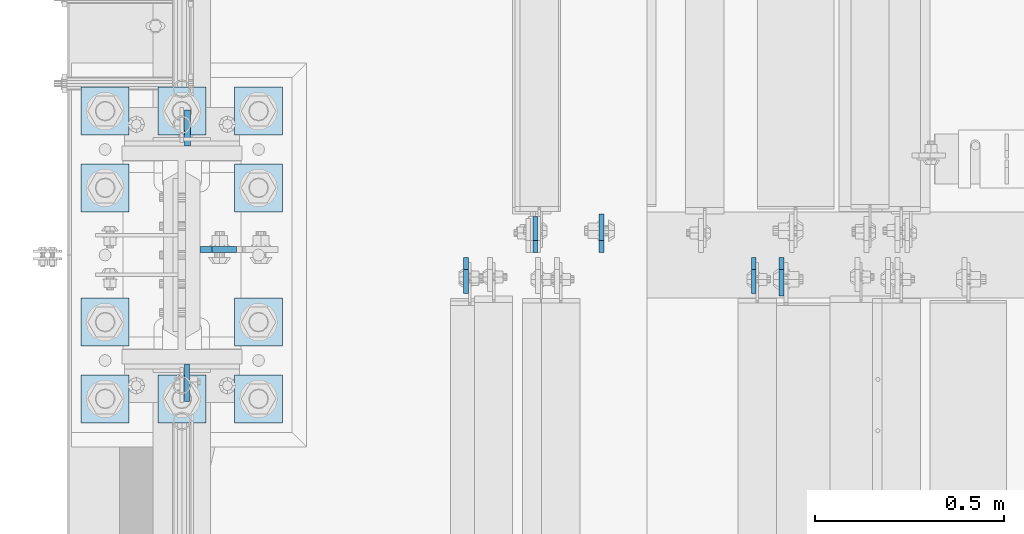
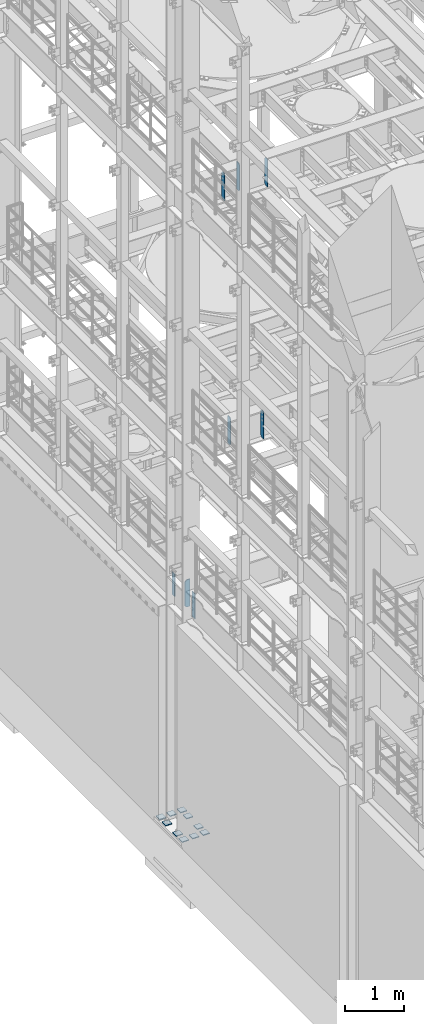
# One storey, part 1694 of 1876: 18 plates, 4 elements without a shape of their own.
"""IFC2X3 building model written with IfcOpenShell, lengths in millimetres."""

import ifcopenshell
import ifcopenshell.guid

model = None  # the IFC model being written
_history = None  # IfcOwnerHistory: only IFC2X3 demands one
_inside = {}  # id of a spatial element -> (the spatial element, [elements in it])
_under = {}  # id of a project, library or spatial element -> (it, [spatial elements below it])
_declared = {}  # id of a project -> (the project, [libraries it declares])
_typed = {}  # id of a type object -> (the type object, [elements of that type])
_made_of = {}  # id of a material, layer set ... -> (it, [elements and type objects made of it])


def new_model(schema):
    """Start an empty IFC model of exactly this schema.

    Asked for "IFC4X3", IfcOpenShell would pick the latest addendum, in which some entities
    have other attributes; the version numbers below select the first issue.
    IFC2X3 requires an IfcOwnerHistory on every rooted entity: one is made here for all.
    """
    global model, _history
    if schema == "IFC4X3":
        model = ifcopenshell.file(schema_version=(4, 3, 0, 0))
    else:
        model = ifcopenshell.file(schema=schema)
    _inside.clear()
    _under.clear()
    _declared.clear()
    _typed.clear()
    _made_of.clear()
    _history = None
    if model.schema == "IFC2X3":
        org = make("IfcOrganization", Name="unknown")
        user = make(
            "IfcPersonAndOrganization",
            ThePerson=make("IfcPerson", FamilyName="unknown"),
            TheOrganization=org,
        )
        app = make(
            "IfcApplication",
            ApplicationDeveloper=org,
            Version="unknown",
            ApplicationFullName="unknown",
            ApplicationIdentifier="unknown",
        )
        _history = make(
            "IfcOwnerHistory",
            OwningUser=user,
            OwningApplication=app,
            ChangeAction="ADDED",
            CreationDate=0,
        )
    return model


def make(cls, **values):
    """One entity of the class cls with the attributes given. An attribute that is None is left unset."""
    return model.create_entity(
        cls, **{name: value for name, value in values.items() if value is not None}
    )


def rooted(cls, **values):
    """An entity with a GlobalId (a new one), such as an element, a storey or a relation."""
    return make(cls, GlobalId=ifcopenshell.guid.new(), OwnerHistory=_history, **values)


def si_unit(unit_type, name, prefix=None):
    """IfcSIUnit, for example si_unit("LENGTHUNIT", "METRE", prefix="MILLI")."""
    return make("IfcSIUnit", UnitType=unit_type, Prefix=prefix, Name=name)


def assignment(units):
    """IfcUnitAssignment: the units of a project."""
    return None if units is None else make("IfcUnitAssignment", Units=units)


def point(xyz):
    """IfcCartesianPoint."""
    return None if xyz is None else make("IfcCartesianPoint", Coordinates=xyz)


def direction(xyz):
    """IfcDirection."""
    return None if xyz is None else make("IfcDirection", DirectionRatios=xyz)


def frame(location, z_axis=None, x_axis=None):
    """IfcAxis2Placement3D, a coordinate frame: its origin and axes. An axis left out is left unset."""
    return make(
        "IfcAxis2Placement3D",
        Location=point(location),
        Axis=direction(z_axis),
        RefDirection=direction(x_axis),
    )


def origin_with_axes():
    """The frame at (0, 0, 0) with the z axis (0, 0, 1) and the x axis (1, 0, 0) written out."""
    return frame((0.0, 0.0, 0.0), z_axis=(0.0, 0.0, 1.0), x_axis=(1.0, 0.0, 0.0))


def place(relative_to, where):
    """IfcLocalPlacement: puts the frame where relative to a parent placement (None: the world)."""
    return make(
        "IfcLocalPlacement", PlacementRelTo=relative_to, RelativePlacement=where
    )


def context(
    kind, dimensions, precision=None, world=None, true_north=None, identifier=None
):
    """IfcGeometricRepresentationContext, for example the 3D "Model" context."""
    return make(
        "IfcGeometricRepresentationContext",
        ContextIdentifier=identifier,
        ContextType=kind,
        CoordinateSpaceDimension=dimensions,
        Precision=precision,
        WorldCoordinateSystem=world,
        TrueNorth=true_north,
    )


def subcontext(parent, identifier, kind, view, scale=None):
    """IfcGeometricRepresentationSubContext, for example "Body" below "Model"."""
    return make(
        "IfcGeometricRepresentationSubContext",
        ContextIdentifier=identifier,
        ContextType=kind,
        ParentContext=parent,
        TargetScale=scale,
        TargetView=view,
    )


def project(units=None, contexts=None):
    """IfcProject with its units and contexts."""
    return rooted(
        "IfcProject",
        Name="project",
        RepresentationContexts=contexts,
        UnitsInContext=assignment(units),
    )


def spatial(cls, under=None, at=None, **own):
    """A site, building, storey or space (cls), placed at a placement, below another one or the project."""
    s = rooted(cls, ObjectPlacement=at, **own)
    if under is not None:
        _under.setdefault(under.id(), (under, []))[1].append(s)
    return s


def faces_of(points, faces, orient=None, outer=None):
    """IfcFace entities. A face is a list of loops; a loop is a list of indices into points, from 0.

    orient and outer hold one flag for each loop. By default every Orientation is true, the
    first loop of a face is its IfcFaceOuterBound and the others are IfcFaceBound.
    """
    made = []
    for i, loops in enumerate(faces):
        bounds = []
        for j, loop in enumerate(loops):
            is_outer = j == 0 if outer is None else outer[i][j]
            bounds.append(
                make(
                    "IfcFaceOuterBound" if is_outer else "IfcFaceBound",
                    Bound=make("IfcPolyLoop", Polygon=[points[k] for k in loop]),
                    Orientation=True if orient is None else orient[i][j],
                )
            )
        made.append(make("IfcFace", Bounds=bounds))
    return made


def faceted_brep(points, faces, orient=None, outer=None, voids=None):
    """IfcFacetedBrep: a solid bounded by flat faces; with voids (closed shells), ...WithVoids."""
    shared = [point(p) for p in points]
    hull = make("IfcClosedShell", CfsFaces=faces_of(shared, faces, orient, outer))
    if voids is None:
        return make("IfcFacetedBrep", Outer=hull)
    return make(
        "IfcFacetedBrepWithVoids",
        Outer=hull,
        Voids=[
            make(cls, CfsFaces=faces_of(shared, fs, o, b)) for cls, fs, o, b in voids
        ],
    )


def shape(context_of_items, identifier, shape_type, items):
    """IfcShapeRepresentation: the items that make up one representation, for example the "Body"."""
    return make(
        "IfcShapeRepresentation",
        ContextOfItems=context_of_items,
        RepresentationIdentifier=identifier,
        RepresentationType=shape_type,
        Items=items,
    )


def material(Name=None, Category=None):
    """IfcMaterial."""
    return make("IfcMaterial", Name=Name, Category=Category)


def made_of(thing, what):
    """Note that an element or type object is made of a material, layer set ...; save() writes the relation."""
    if what is not None:
        _made_of.setdefault(what.id(), (what, []))[1].append(thing)
    return thing


def type_object(cls, material=None, **own):
    """A type object (cls), such as IfcWallType, which elements share."""
    return made_of(rooted(cls, **own), material)


def element(
    cls,
    number,
    at=None,
    inside=None,
    cuts=None,
    type_object=None,
    material=None,
    context=None,
    identifier="Body",
    shape_type=None,
    held_by="IfcProductDefinitionShape",
    body=None,
    shapes=None,
    **own,
):
    """One element of the class cls, such as IfcWall. Its Tag is "e" and its number.

    at: its placement. inside: the storey or other place that contains it. cuts: it is an
    opening in that element (IfcRelVoidsElement). A single representation is given by context,
    identifier, shape_type and body (its items); several are given by shapes. held_by: the class
    of the entity that holds the representations. save() writes the other relations.
    """
    e = rooted(cls, Tag="e%d" % number, ObjectPlacement=at, **own)
    if body is not None:
        shapes = [shape(context, identifier, shape_type, body)]
    if shapes is not None:
        e.Representation = make(held_by, Representations=shapes)
    if inside is not None:
        _inside.setdefault(inside.id(), (inside, []))[1].append(e)
    if cuts is not None:
        rooted(
            "IfcRelVoidsElement", RelatingBuildingElement=cuts, RelatedOpeningElement=e
        )
    if type_object is not None:
        _typed.setdefault(type_object.id(), (type_object, []))[1].append(e)
    return made_of(e, material)


def aggregate(whole, parts):
    """IfcRelAggregates: a whole, such as a stair, and the parts it consists of."""
    return rooted("IfcRelAggregates", RelatingObject=whole, RelatedObjects=parts)


def save(model, path):
    """Write the relations noted so far, then the file.

    IfcRelAggregates (storeys below a building ...), IfcRelContainedInSpatialStructure (elements
    in a storey), IfcRelDefinesByType, IfcRelAssociatesMaterial and IfcRelDeclares: one each for
    every whole, place, type object, material and project.
    """
    for whole, parts in _under.values():
        aggregate(whole, parts)
    for where, things in _inside.values():
        rooted(
            "IfcRelContainedInSpatialStructure",
            RelatedElements=things,
            RelatingStructure=where,
        )
    for kind, things in _typed.values():
        rooted("IfcRelDefinesByType", RelatedObjects=things, RelatingType=kind)
    for what, things in _made_of.values():
        rooted("IfcRelAssociatesMaterial", RelatedObjects=things, RelatingMaterial=what)
    for by, libraries in _declared.values():
        rooted("IfcRelDeclares", RelatingContext=by, RelatedDefinitions=libraries)
    model.write(path)


model = new_model("IFC2X3")

# Units and contexts
model_context = context("Model", 3, precision=1e-05, world=origin_with_axes())
body_context = subcontext(model_context, "Body", "Model", "MODEL_VIEW")
ifc_project = project(units=[si_unit("LENGTHUNIT", "METRE", prefix="MILLI"), si_unit("AREAUNIT", "SQUARE_METRE"), si_unit("VOLUMEUNIT", "CUBIC_METRE"), si_unit("MASSUNIT", "GRAM", prefix="KILO"), si_unit("TIMEUNIT", "SECOND"), si_unit("PLANEANGLEUNIT", "RADIAN"), si_unit("SOLIDANGLEUNIT", "STERADIAN"), si_unit("THERMODYNAMICTEMPERATUREUNIT", "DEGREE_CELSIUS"), si_unit("LUMINOUSINTENSITYUNIT", "LUMEN")], contexts=[model_context])

# Site, building, storey
site_placement = place(None, origin_with_axes())
site = spatial("IfcSite", under=ifc_project, at=site_placement, CompositionType="ELEMENT")
building_placement = place(site_placement, origin_with_axes())
building = spatial("IfcBuilding", under=site, at=building_placement, Name="Undefined", CompositionType="ELEMENT")
storey_placement = place(building_placement, origin_with_axes())
storey = spatial("IfcBuildingStorey", under=building, at=storey_placement, Name="Undefined", CompositionType="ELEMENT", Elevation=0.0)

# Assembly, plate
assembly_1_placement = place(storey_placement, origin_with_axes())
assembly_1 = element("IfcElementAssembly", 1, at=assembly_1_placement, inside=storey, Name="COLUMN", AssemblyPlace="NOTDEFINED", PredefinedType="RIGID_FRAME")
ifc_material_1 = material(Name="STEEL/A572-50")
plate_type_1 = type_object("IfcPlateType", PredefinedType="NOTDEFINED")
plate_1_placement = place(assembly_1_placement, frame((13.493000125885, 7331.075, 5076.825), z_axis=(0.0, -1.0, 0.0), x_axis=(0.0, 0.0, -1.0)))
plate_1 = element("IfcPlate", 2, at=plate_1_placement, type_object=plate_type_1, material=ifc_material_1, Name="PLATE", context=body_context, shape_type="Brep", body=[
    faceted_brep([(0.0, -6.35000000000036, 0.0), (0.0, -6.34999999999991, 98.4250030517578), (0.0, 6.34999999999991, 98.4250030517578), (0.0, 6.35000000000036, 0.0), (514.349975585938, -6.35000000000036, 98.4250030517578), (514.349975585938, 6.35000000000036, 98.4250030517578), (514.349975585938, -6.35000000000036, 0.0), (514.349975585938, 6.35000000000036, 0.0)], [[[0, 1, 2, 3]], [[1, 4, 5, 2]], [[4, 6, 7, 5]], [[6, 0, 3, 7]], [[5, 7, 3, 2]], [[6, 4, 1, 0]]]),
])

# Assembly, plates
assembly_2_placement = place(storey_placement, origin_with_axes())
assembly_2 = element("IfcElementAssembly", 3, at=assembly_2_placement, inside=storey, Name="BEAM", AssemblyPlace="NOTDEFINED", PredefinedType="RIGID_FRAME")
ifc_material_2 = material(Name="STEEL/A36")
plate_type_2 = type_object("IfcPlateType", PredefinedType="NOTDEFINED")
plate_2_placement = place(assembly_2_placement, frame((1514.47512197494, 7612.85625, 7558.0875), z_axis=(0.0, 0.0, 1.0), x_axis=(0.0, -1.0, 0.0)))
plate_2 = element("IfcPlate", 4, at=plate_2_placement, type_object=plate_type_2, material=ifc_material_2, Name="PLATE", context=body_context, shape_type="Brep", body=[
    faceted_brep([(0.0, -6.34999999999991, 31.75), (0.0, -6.35000000000036, 538.162475585938), (0.0, 6.35000000000036, 538.162475585938), (0.0, 6.34999999999991, 31.75), (31.75, -6.35000000000036, 569.912475585938), (31.75, 6.35000000000036, 569.912475585938), (95.25, -6.35000000000036, 569.912475585938), (95.25, 6.35000000000036, 569.912475585938), (95.25, -6.35000000000036, 0.0), (95.25, 6.35000000000036, 0.0), (31.75, -6.34999999999991, 0.0), (31.75, 6.34999999999991, 0.0)], [[[0, 1, 2, 3]], [[1, 4, 5, 2]], [[4, 6, 7, 5]], [[6, 8, 9, 7]], [[8, 10, 11, 9]], [[10, 0, 3, 11]], [[5, 7, 9, 11, 3, 2]], [[10, 8, 6, 4, 1, 0]]]),
])
plate_3_placement = place(assembly_2_placement, frame((936.624999904632, 7627.14375, 7558.0875), z_axis=(0.0, 0.0, 1.0), x_axis=(0.0, 1.0, 0.0)))
plate_3 = element("IfcPlate", 5, at=plate_3_placement, type_object=plate_type_2, material=ifc_material_2, Name="PLATE", context=body_context, shape_type="Brep", body=[
    faceted_brep([(0.0, -6.34999999999991, 31.75), (0.0, -6.35000000000036, 538.162475585938), (0.0, 6.35000000000036, 538.162475585938), (0.0, 6.34999999999991, 31.75), (31.75, -6.35000000000036, 569.912475585938), (31.75, 6.35000000000036, 569.912475585938), (95.25, -6.35000000000036, 569.912475585938), (95.25, 6.35000000000036, 569.912475585938), (95.25, -6.35000000000036, 0.0), (95.25, 6.35000000000036, 0.0), (31.75, -6.34999999999991, 0.0), (31.75, 6.34999999999991, 0.0)], [[[0, 1, 2, 3]], [[1, 4, 5, 2]], [[4, 6, 7, 5]], [[6, 8, 9, 7]], [[8, 10, 11, 9]], [[10, 0, 3, 11]], [[5, 7, 9, 11, 3, 2]], [[10, 8, 6, 4, 1, 0]]]),
])
aggregate(assembly_2, [plate_2, plate_3])

assembly_3_placement = place(storey_placement, origin_with_axes())
assembly_3 = element("IfcElementAssembly", 6, at=assembly_3_placement, inside=storey, Name="BEAM", AssemblyPlace="NOTDEFINED", PredefinedType="RIGID_FRAME")
plate_4_placement = place(assembly_3_placement, frame((752.474999904632, 7612.85625, 12714.2875), z_axis=(0.0, 0.0, 1.0), x_axis=(0.0, -1.0, 0.0)))
plate_4 = element("IfcPlate", 7, at=plate_4_placement, type_object=plate_type_2, material=ifc_material_2, Name="PLATE", context=body_context, shape_type="Brep", body=[
    faceted_brep([(0.0, -6.34999999999991, 31.75), (0.0, -6.35000000000036, 538.162475585938), (0.0, 6.35000000000036, 538.162475585938), (0.0, 6.34999999999991, 31.75), (31.75, -6.35000000000036, 569.912475585938), (31.75, 6.35000000000036, 569.912475585938), (95.25, -6.35000000000036, 569.912475585938), (95.25, 6.35000000000036, 569.912475585938), (95.25, -6.35000000000036, 0.0), (95.25, 6.35000000000036, 0.0), (31.75, -6.34999999999991, 0.0), (31.75, 6.34999999999991, 0.0)], [[[0, 1, 2, 3]], [[1, 4, 5, 2]], [[4, 6, 7, 5]], [[6, 8, 9, 7]], [[8, 10, 11, 9]], [[10, 0, 3, 11]], [[5, 7, 9, 11, 3, 2]], [[10, 8, 6, 4, 1, 0]]]),
])
plate_type_3 = type_object("IfcPlateType", PredefinedType="NOTDEFINED")
plate_5_placement = place(assembly_3_placement, frame((1111.25000470527, 7627.14375, 12714.2875), z_axis=(0.0, 0.0, 1.0), x_axis=(0.0, 1.0, 0.0)))
plate_5 = element("IfcPlate", 8, at=plate_5_placement, type_object=plate_type_3, material=ifc_material_2, Name="PLATE", context=body_context, shape_type="Brep", body=[
    faceted_brep([(0.0, -6.34999999999991, 31.75), (0.0, -6.35000000000036, 538.162475585938), (0.0, 6.35000000000036, 538.162475585938), (0.0, 6.34999999999991, 31.75), (31.75, -6.35000000000036, 569.912475585938), (31.75, 6.35000000000036, 569.912475585938), (101.599998474121, -6.34999999999991, 569.912475585938), (101.599998474121, 6.34999999999991, 569.912475585938), (101.599998474121, -6.35000000000036, 0.0), (101.599998474121, 6.35000000000036, 0.0), (31.75, -6.34999999999991, 0.0), (31.75, 6.34999999999991, 0.0)], [[[0, 1, 2, 3]], [[1, 4, 5, 2]], [[4, 6, 7, 5]], [[6, 8, 9, 7]], [[8, 10, 11, 9]], [[10, 0, 3, 11]], [[5, 7, 9, 11, 3, 2]], [[10, 8, 6, 4, 1, 0]]]),
])
plate_6_placement = place(assembly_3_placement, frame((1588.29374990463, 7612.85625, 12714.2875), z_axis=(0.0, 0.0, 1.0), x_axis=(0.0, -1.0, 0.0)))
plate_6 = element("IfcPlate", 9, at=plate_6_placement, type_object=plate_type_3, material=ifc_material_2, Name="PLATE", context=body_context, shape_type="Brep", body=[
    faceted_brep([(0.0, -6.34999999999991, 31.75), (0.0, -6.35000000000036, 538.162475585938), (0.0, 6.35000000000036, 538.162475585938), (0.0, 6.34999999999991, 31.75), (31.75, -6.35000000000036, 569.912475585938), (31.75, 6.35000000000036, 569.912475585938), (101.599998474121, -6.34999999999991, 569.912475585938), (101.599998474121, 6.34999999999991, 569.912475585938), (101.599998474121, -6.35000000000036, 0.0), (101.599998474121, 6.35000000000036, 0.0), (31.75, -6.34999999999991, 0.0), (31.75, 6.34999999999991, 0.0)], [[[0, 1, 2, 3]], [[1, 4, 5, 2]], [[4, 6, 7, 5]], [[6, 8, 9, 7]], [[8, 10, 11, 9]], [[10, 0, 3, 11]], [[5, 7, 9, 11, 3, 2]], [[10, 8, 6, 4, 1, 0]]]),
])
aggregate(assembly_3, [plate_5, plate_4, plate_6])

# Plate
plate_type_4 = type_object("IfcPlateType", PredefinedType="NOTDEFINED")
plate_7_placement = place(assembly_1_placement, frame((48.4187500000005, 7635.08050012589, 5099.05), z_axis=(1.0, 0.0, 0.0), x_axis=(0.0, 0.0, -1.0)))
plate_7 = element("IfcPlate", 10, at=plate_7_placement, type_object=plate_type_4, material=ifc_material_2, Name="PLATE", context=body_context, shape_type="Brep", body=[
    faceted_brep([(0.0, -7.93749999999998, 31.75), (0.0, -7.9375, 96.0437469482422), (0.0, 7.9375, 96.0437469482422), (0.0, 7.93749999999999, 31.75), (558.799987792969, -7.9375, 96.0437469482422), (558.799987792969, 7.9375, 96.0437469482422), (558.799987792969, -7.93749999999998, 31.75), (558.799987792969, 7.93749999999999, 31.75), (527.049987792969, -7.93749999999998, 0.0), (527.049987792969, 7.93749999999999, 0.0), (31.75, -7.93749999999998, 0.0), (31.75, 7.93749999999999, 0.0)], [[[0, 1, 2, 3]], [[1, 4, 5, 2]], [[4, 6, 7, 5]], [[6, 8, 9, 7]], [[8, 10, 11, 9]], [[10, 0, 3, 11]], [[5, 7, 9, 11, 3, 2]], [[10, 8, 6, 4, 1, 0]]]),
])

plate_8_placement = place(assembly_1_placement, frame((15.080500125885, 7908.925, 5067.3), z_axis=(0.0, 1.0, 0.0), x_axis=(0.0, 0.0, -1.0)))
plate_8 = element("IfcPlate", 11, at=plate_8_placement, type_object=plate_type_4, material=ifc_material_2, Name="PLATE", context=body_context, shape_type="Brep", body=[
    faceted_brep([(0.0, -7.9375, 0.0), (0.0, -7.9375, 95.25), (0.0, 7.9375, 95.25), (0.0, 7.9375, 0.0), (457.200012207031, -7.9375, 95.25), (457.200012207031, 7.9375, 95.25), (457.200012207031, -7.9375, 0.0), (457.200012207031, 7.9375, 0.0)], [[[0, 1, 2, 3]], [[1, 4, 5, 2]], [[4, 6, 7, 5]], [[6, 0, 3, 7]], [[5, 7, 3, 2]], [[6, 4, 1, 0]]]),
])

aggregate(assembly_1, [plate_7, plate_1, plate_8])

# Assembly, plates
assembly_4_placement = place(storey_placement, origin_with_axes())
assembly_4 = element("IfcElementAssembly", 12, at=assembly_4_placement, inside=storey, Name="TEMPLATE", AssemblyPlace="NOTDEFINED", PredefinedType="RIGID_FRAME")
plate_type_5 = type_object("IfcPlateType", PredefinedType="NOTDEFINED")
plate_9_placement = place(assembly_4_placement, frame((-139.7, 7302.5, 104.775), z_axis=(-1.0, 0.0, 0.0), x_axis=(0.0, -1.0, 0.0)))
plate_9 = element("IfcPlate", 13, at=plate_9_placement, type_object=plate_type_5, material=ifc_material_1, Name="PLATE WASHER", context=body_context, shape_type="Brep", body=[
    faceted_brep([(-9.09494701772928e-13, -9.525, -1.81898940354586e-12), (0.0, -9.52500000000001, 127.0), (0.0, 9.52500000000001, 127.0), (-9.09494701772928e-13, 9.525, -1.81898940354586e-12), (127.0, -9.52500000000001, 127.0), (127.0, 9.52500000000001, 127.0), (127.0, -9.52500000000001, 0.0), (127.0, 9.52500000000001, 0.0)], [[[0, 1, 2, 3]], [[1, 4, 5, 2]], [[4, 6, 7, 5]], [[6, 0, 3, 7]], [[5, 7, 3, 2]], [[6, 4, 1, 0]]]),
])
plate_10_placement = place(assembly_4_placement, frame((63.5, 7302.5, 104.775), z_axis=(-1.0, 0.0, 0.0), x_axis=(0.0, -1.0, 0.0)))
plate_10 = element("IfcPlate", 14, at=plate_10_placement, type_object=plate_type_5, material=ifc_material_1, Name="PLATE WASHER", context=body_context, shape_type="Brep", body=[
    faceted_brep([(-9.09494701772928e-13, -9.525, -1.81898940354586e-12), (0.0, -9.52500000000001, 127.0), (0.0, 9.52500000000001, 127.0), (-9.09494701772928e-13, 9.525, -1.81898940354586e-12), (127.0, -9.52500000000001, 127.0), (127.0, 9.52500000000001, 127.0), (127.0, -9.52500000000001, 0.0), (127.0, 9.52500000000001, 0.0)], [[[0, 1, 2, 3]], [[1, 4, 5, 2]], [[4, 6, 7, 5]], [[6, 0, 3, 7]], [[5, 7, 3, 2]], [[6, 4, 1, 0]]]),
])
plate_11_placement = place(assembly_4_placement, frame((266.7, 7302.5, 104.775), z_axis=(-1.0, 0.0, 0.0), x_axis=(0.0, -1.0, 0.0)))
plate_11 = element("IfcPlate", 15, at=plate_11_placement, type_object=plate_type_5, material=ifc_material_1, Name="PLATE WASHER", context=body_context, shape_type="Brep", body=[
    faceted_brep([(-9.09494701772928e-13, -9.525, -1.81898940354586e-12), (0.0, -9.52500000000001, 127.0), (0.0, 9.52500000000001, 127.0), (-9.09494701772928e-13, 9.525, -1.81898940354586e-12), (127.0, -9.52500000000001, 127.0), (127.0, 9.52500000000001, 127.0), (127.0, -9.52500000000001, 0.0), (127.0, 9.52500000000001, 0.0)], [[[0, 1, 2, 3]], [[1, 4, 5, 2]], [[4, 6, 7, 5]], [[6, 0, 3, 7]], [[5, 7, 3, 2]], [[6, 4, 1, 0]]]),
])
plate_12_placement = place(assembly_4_placement, frame((-139.7, 7505.7, 104.775), z_axis=(-1.0, 0.0, 0.0), x_axis=(0.0, -1.0, 0.0)))
plate_12 = element("IfcPlate", 16, at=plate_12_placement, type_object=plate_type_5, material=ifc_material_1, Name="PLATE WASHER", context=body_context, shape_type="Brep", body=[
    faceted_brep([(-9.09494701772928e-13, -9.525, -1.81898940354586e-12), (0.0, -9.52500000000001, 127.0), (0.0, 9.52500000000001, 127.0), (-9.09494701772928e-13, 9.525, -1.81898940354586e-12), (127.0, -9.52500000000001, 127.0), (127.0, 9.52500000000001, 127.0), (127.0, -9.52500000000001, 0.0), (127.0, 9.52500000000001, 0.0)], [[[0, 1, 2, 3]], [[1, 4, 5, 2]], [[4, 6, 7, 5]], [[6, 0, 3, 7]], [[5, 7, 3, 2]], [[6, 4, 1, 0]]]),
])
plate_13_placement = place(assembly_4_placement, frame((266.7, 7505.7, 104.775), z_axis=(-1.0, 0.0, 0.0), x_axis=(0.0, -1.0, 0.0)))
plate_13 = element("IfcPlate", 17, at=plate_13_placement, type_object=plate_type_5, material=ifc_material_1, Name="PLATE WASHER", context=body_context, shape_type="Brep", body=[
    faceted_brep([(-9.09494701772928e-13, -9.525, -1.81898940354586e-12), (0.0, -9.52500000000001, 127.0), (0.0, 9.52500000000001, 127.0), (-9.09494701772928e-13, 9.525, -1.81898940354586e-12), (127.0, -9.52500000000001, 127.0), (127.0, 9.52500000000001, 127.0), (127.0, -9.52500000000001, 0.0), (127.0, 9.52500000000001, 0.0)], [[[0, 1, 2, 3]], [[1, 4, 5, 2]], [[4, 6, 7, 5]], [[6, 0, 3, 7]], [[5, 7, 3, 2]], [[6, 4, 1, 0]]]),
])
plate_14_placement = place(assembly_4_placement, frame((-139.7, 7861.3, 104.775), z_axis=(-1.0, 0.0, 0.0), x_axis=(0.0, -1.0, 0.0)))
plate_14 = element("IfcPlate", 18, at=plate_14_placement, type_object=plate_type_5, material=ifc_material_1, Name="PLATE WASHER", context=body_context, shape_type="Brep", body=[
    faceted_brep([(-9.09494701772928e-13, -9.525, -1.81898940354586e-12), (0.0, -9.52500000000001, 127.0), (0.0, 9.52500000000001, 127.0), (-9.09494701772928e-13, 9.525, -1.81898940354586e-12), (127.0, -9.52500000000001, 127.0), (127.0, 9.52500000000001, 127.0), (127.0, -9.52500000000001, 0.0), (127.0, 9.52500000000001, 0.0)], [[[0, 1, 2, 3]], [[1, 4, 5, 2]], [[4, 6, 7, 5]], [[6, 0, 3, 7]], [[5, 7, 3, 2]], [[6, 4, 1, 0]]]),
])
plate_15_placement = place(assembly_4_placement, frame((266.7, 7861.3, 104.775), z_axis=(-1.0, 0.0, 0.0), x_axis=(0.0, -1.0, 0.0)))
plate_15 = element("IfcPlate", 19, at=plate_15_placement, type_object=plate_type_5, material=ifc_material_1, Name="PLATE WASHER", context=body_context, shape_type="Brep", body=[
    faceted_brep([(-9.09494701772928e-13, -9.525, -1.81898940354586e-12), (0.0, -9.52500000000001, 127.0), (0.0, 9.52500000000001, 127.0), (-9.09494701772928e-13, 9.525, -1.81898940354586e-12), (127.0, -9.52500000000001, 127.0), (127.0, 9.52500000000001, 127.0), (127.0, -9.52500000000001, 0.0), (127.0, 9.52500000000001, 0.0)], [[[0, 1, 2, 3]], [[1, 4, 5, 2]], [[4, 6, 7, 5]], [[6, 0, 3, 7]], [[5, 7, 3, 2]], [[6, 4, 1, 0]]]),
])
plate_16_placement = place(assembly_4_placement, frame((-139.7, 8064.5, 104.775), z_axis=(-1.0, 0.0, 0.0), x_axis=(0.0, -1.0, 0.0)))
plate_16 = element("IfcPlate", 20, at=plate_16_placement, type_object=plate_type_5, material=ifc_material_1, Name="PLATE WASHER", context=body_context, shape_type="Brep", body=[
    faceted_brep([(-9.09494701772928e-13, -9.525, -1.81898940354586e-12), (0.0, -9.52500000000001, 127.0), (0.0, 9.52500000000001, 127.0), (-9.09494701772928e-13, 9.525, -1.81898940354586e-12), (127.0, -9.52500000000001, 127.0), (127.0, 9.52500000000001, 127.0), (127.0, -9.52500000000001, 0.0), (127.0, 9.52500000000001, 0.0)], [[[0, 1, 2, 3]], [[1, 4, 5, 2]], [[4, 6, 7, 5]], [[6, 0, 3, 7]], [[5, 7, 3, 2]], [[6, 4, 1, 0]]]),
])
plate_17_placement = place(assembly_4_placement, frame((63.5, 8064.5, 104.775), z_axis=(-1.0, 0.0, 0.0), x_axis=(0.0, -1.0, 0.0)))
plate_17 = element("IfcPlate", 21, at=plate_17_placement, type_object=plate_type_5, material=ifc_material_1, Name="PLATE WASHER", context=body_context, shape_type="Brep", body=[
    faceted_brep([(-9.09494701772928e-13, -9.525, -1.81898940354586e-12), (0.0, -9.52500000000001, 127.0), (0.0, 9.52500000000001, 127.0), (-9.09494701772928e-13, 9.525, -1.81898940354586e-12), (127.0, -9.52500000000001, 127.0), (127.0, 9.52500000000001, 127.0), (127.0, -9.52500000000001, 0.0), (127.0, 9.52500000000001, 0.0)], [[[0, 1, 2, 3]], [[1, 4, 5, 2]], [[4, 6, 7, 5]], [[6, 0, 3, 7]], [[5, 7, 3, 2]], [[6, 4, 1, 0]]]),
])
plate_18_placement = place(assembly_4_placement, frame((266.7, 8064.5, 104.775), z_axis=(-1.0, 0.0, 0.0), x_axis=(0.0, -1.0, 0.0)))
plate_18 = element("IfcPlate", 22, at=plate_18_placement, type_object=plate_type_5, material=ifc_material_1, Name="PLATE WASHER", context=body_context, shape_type="Brep", body=[
    faceted_brep([(-9.09494701772928e-13, -9.525, -1.81898940354586e-12), (0.0, -9.52500000000001, 127.0), (0.0, 9.52500000000001, 127.0), (-9.09494701772928e-13, 9.525, -1.81898940354586e-12), (127.0, -9.52500000000001, 127.0), (127.0, 9.52500000000001, 127.0), (127.0, -9.52500000000001, 0.0), (127.0, 9.52500000000001, 0.0)], [[[0, 1, 2, 3]], [[1, 4, 5, 2]], [[4, 6, 7, 5]], [[6, 0, 3, 7]], [[5, 7, 3, 2]], [[6, 4, 1, 0]]]),
])
aggregate(assembly_4, [plate_9, plate_10, plate_11, plate_12, plate_13, plate_14, plate_15, plate_16, plate_17, plate_18])

save(model, "model.ifc")
